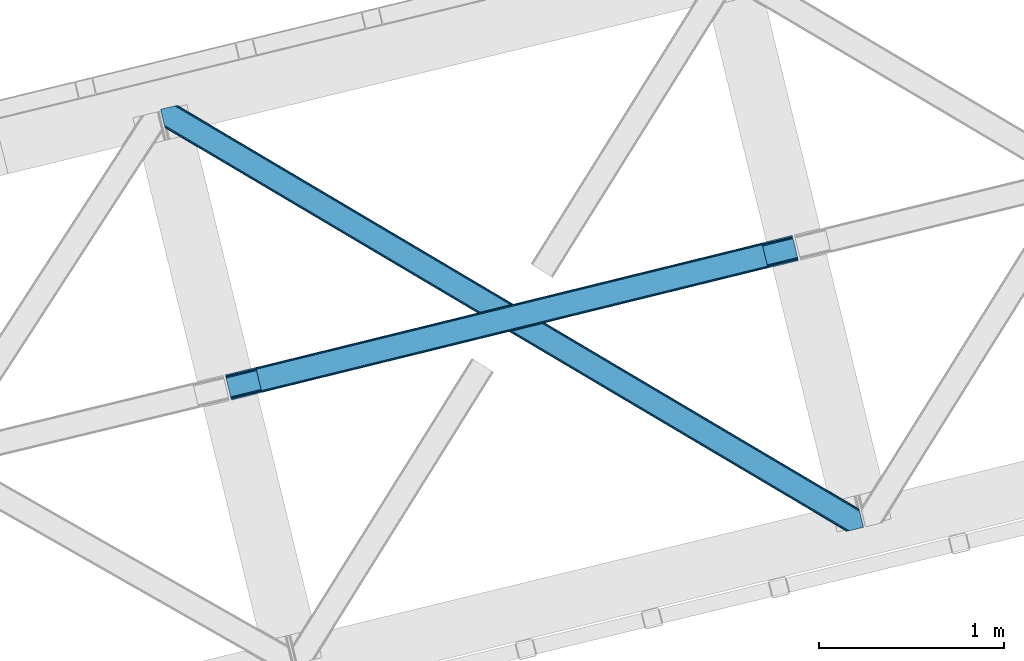
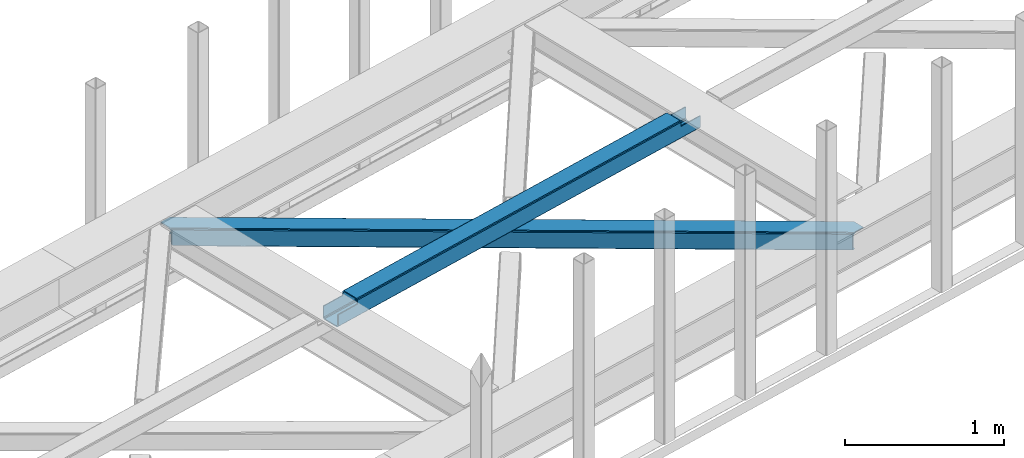
# One storey, part 39 of 66: 1 beam, 1 member.
"""IFC4 building model written with IfcOpenShell, lengths in millimetres."""

import ifcopenshell
import ifcopenshell.guid

model = None  # the IFC model being written
_history = None  # IfcOwnerHistory: only IFC2X3 demands one
_inside = {}  # id of a spatial element -> (the spatial element, [elements in it])
_under = {}  # id of a project, library or spatial element -> (it, [spatial elements below it])
_declared = {}  # id of a project -> (the project, [libraries it declares])
_typed = {}  # id of a type object -> (the type object, [elements of that type])
_made_of = {}  # id of a material, layer set ... -> (it, [elements and type objects made of it])


def new_model(schema):
    """Start an empty IFC model of exactly this schema.

    Asked for "IFC4X3", IfcOpenShell would pick the latest addendum, in which some entities
    have other attributes; the version numbers below select the first issue.
    IFC2X3 requires an IfcOwnerHistory on every rooted entity: one is made here for all.
    """
    global model, _history
    if schema == "IFC4X3":
        model = ifcopenshell.file(schema_version=(4, 3, 0, 0))
    else:
        model = ifcopenshell.file(schema=schema)
    _inside.clear()
    _under.clear()
    _declared.clear()
    _typed.clear()
    _made_of.clear()
    _history = None
    if model.schema == "IFC2X3":
        org = make("IfcOrganization", Name="unknown")
        user = make(
            "IfcPersonAndOrganization",
            ThePerson=make("IfcPerson", FamilyName="unknown"),
            TheOrganization=org,
        )
        app = make(
            "IfcApplication",
            ApplicationDeveloper=org,
            Version="unknown",
            ApplicationFullName="unknown",
            ApplicationIdentifier="unknown",
        )
        _history = make(
            "IfcOwnerHistory",
            OwningUser=user,
            OwningApplication=app,
            ChangeAction="ADDED",
            CreationDate=0,
        )
    return model


def make(cls, **values):
    """One entity of the class cls with the attributes given. An attribute that is None is left unset."""
    return model.create_entity(
        cls, **{name: value for name, value in values.items() if value is not None}
    )


def entity(cls, *values):
    """Any entity or typed value of the class cls, its attributes in the order of the schema. None: left unset."""
    e = model.create_entity(cls)
    for i, value in enumerate(values):
        if value is not None:
            e[i] = value
    return e


def rooted(cls, **values):
    """An entity with a GlobalId (a new one), such as an element, a storey or a relation."""
    return make(cls, GlobalId=ifcopenshell.guid.new(), OwnerHistory=_history, **values)


def si_unit(unit_type, name, prefix=None):
    """IfcSIUnit, for example si_unit("LENGTHUNIT", "METRE", prefix="MILLI")."""
    return make("IfcSIUnit", UnitType=unit_type, Prefix=prefix, Name=name)


def converted_unit(unit_type, name, factor, base, dimensions=None, offset=None):
    """IfcConversionBasedUnit, such as the inch: factor (a typed value) times the base unit."""
    return make(
        "IfcConversionBasedUnit"
        if offset is None
        else "IfcConversionBasedUnitWithOffset",
        ConversionOffset=offset,
        Dimensions=None
        if dimensions is None
        else entity("IfcDimensionalExponents", *dimensions),
        UnitType=unit_type,
        Name=name,
        ConversionFactor=make(
            "IfcMeasureWithUnit", ValueComponent=factor, UnitComponent=base
        ),
    )


def derived_unit(unit_type, elements):
    """IfcDerivedUnit: a product of units, each with its exponent."""
    return make(
        "IfcDerivedUnit",
        Elements=[
            make("IfcDerivedUnitElement", Unit=unit, Exponent=power)
            for unit, power in elements
        ],
        UnitType=unit_type,
    )


def assignment(units):
    """IfcUnitAssignment: the units of a project."""
    return None if units is None else make("IfcUnitAssignment", Units=units)


def point(xyz):
    """IfcCartesianPoint."""
    return None if xyz is None else make("IfcCartesianPoint", Coordinates=xyz)


def direction(xyz):
    """IfcDirection."""
    return None if xyz is None else make("IfcDirection", DirectionRatios=xyz)


def frame(location, z_axis=None, x_axis=None):
    """IfcAxis2Placement3D, a coordinate frame: its origin and axes. An axis left out is left unset."""
    return make(
        "IfcAxis2Placement3D",
        Location=point(location),
        Axis=direction(z_axis),
        RefDirection=direction(x_axis),
    )


def origin():
    """The frame at (0, 0, 0) with its axes left unset."""
    return frame((0.0, 0.0, 0.0))


def place(relative_to, where):
    """IfcLocalPlacement: puts the frame where relative to a parent placement (None: the world)."""
    return make(
        "IfcLocalPlacement", PlacementRelTo=relative_to, RelativePlacement=where
    )


def context(
    kind, dimensions, precision=None, world=None, true_north=None, identifier=None
):
    """IfcGeometricRepresentationContext, for example the 3D "Model" context."""
    return make(
        "IfcGeometricRepresentationContext",
        ContextIdentifier=identifier,
        ContextType=kind,
        CoordinateSpaceDimension=dimensions,
        Precision=precision,
        WorldCoordinateSystem=world,
        TrueNorth=true_north,
    )


def subcontext(parent, identifier, kind, view, scale=None):
    """IfcGeometricRepresentationSubContext, for example "Body" below "Model"."""
    return make(
        "IfcGeometricRepresentationSubContext",
        ContextIdentifier=identifier,
        ContextType=kind,
        ParentContext=parent,
        TargetScale=scale,
        TargetView=view,
    )


def project(units=None, contexts=None):
    """IfcProject with its units and contexts."""
    return rooted(
        "IfcProject",
        Name="project",
        RepresentationContexts=contexts,
        UnitsInContext=assignment(units),
    )


def spatial(cls, under=None, at=None, **own):
    """A site, building, storey or space (cls), placed at a placement, below another one or the project."""
    s = rooted(cls, ObjectPlacement=at, **own)
    if under is not None:
        _under.setdefault(under.id(), (under, []))[1].append(s)
    return s


def point_list(points):
    """IfcCartesianPointList2D or 3D."""
    cls = (
        "IfcCartesianPointList2D" if len(points[0]) == 2 else "IfcCartesianPointList3D"
    )
    return make(cls, CoordList=points)


def triangles(points, corners, closed=None, point_numbers=None):
    """IfcTriangulatedFaceSet: each triangle names its three corners, points numbered from 1."""
    return make(
        "IfcTriangulatedFaceSet",
        Coordinates=point_list(points),
        Closed=closed,
        CoordIndex=corners,
        PnIndex=point_numbers,
    )


def polygons(points, faces, closed=None, point_numbers=None):
    """IfcPolygonalFaceSet: a face is its outer loop, then its inner loops; points numbered from 1."""
    made = []
    for loops in faces:
        if len(loops) == 1:
            made.append(make("IfcIndexedPolygonalFace", CoordIndex=loops[0]))
        else:
            made.append(
                make(
                    "IfcIndexedPolygonalFaceWithVoids",
                    CoordIndex=loops[0],
                    InnerCoordIndices=loops[1:],
                )
            )
    return make(
        "IfcPolygonalFaceSet",
        Coordinates=point_list(points),
        Closed=closed,
        Faces=made,
        PnIndex=point_numbers,
    )


def shape(context_of_items, identifier, shape_type, items):
    """IfcShapeRepresentation: the items that make up one representation, for example the "Body"."""
    return make(
        "IfcShapeRepresentation",
        ContextOfItems=context_of_items,
        RepresentationIdentifier=identifier,
        RepresentationType=shape_type,
        Items=items,
    )


def material(Name=None, Category=None):
    """IfcMaterial."""
    return make("IfcMaterial", Name=Name, Category=Category)


def made_of(thing, what):
    """Note that an element or type object is made of a material, layer set ...; save() writes the relation."""
    if what is not None:
        _made_of.setdefault(what.id(), (what, []))[1].append(thing)
    return thing


def type_object(cls, material=None, **own):
    """A type object (cls), such as IfcWallType, which elements share."""
    return made_of(rooted(cls, **own), material)


def element(
    cls,
    number,
    at=None,
    inside=None,
    cuts=None,
    type_object=None,
    material=None,
    context=None,
    identifier="Body",
    shape_type=None,
    held_by="IfcProductDefinitionShape",
    body=None,
    shapes=None,
    **own,
):
    """One element of the class cls, such as IfcWall. Its Tag is "e" and its number.

    at: its placement. inside: the storey or other place that contains it. cuts: it is an
    opening in that element (IfcRelVoidsElement). A single representation is given by context,
    identifier, shape_type and body (its items); several are given by shapes. held_by: the class
    of the entity that holds the representations. save() writes the other relations.
    """
    e = rooted(cls, Tag="e%d" % number, ObjectPlacement=at, **own)
    if body is not None:
        shapes = [shape(context, identifier, shape_type, body)]
    if shapes is not None:
        e.Representation = make(held_by, Representations=shapes)
    if inside is not None:
        _inside.setdefault(inside.id(), (inside, []))[1].append(e)
    if cuts is not None:
        rooted(
            "IfcRelVoidsElement", RelatingBuildingElement=cuts, RelatedOpeningElement=e
        )
    if type_object is not None:
        _typed.setdefault(type_object.id(), (type_object, []))[1].append(e)
    return made_of(e, material)


def aggregate(whole, parts):
    """IfcRelAggregates: a whole, such as a stair, and the parts it consists of."""
    return rooted("IfcRelAggregates", RelatingObject=whole, RelatedObjects=parts)


def save(model, path):
    """Write the relations noted so far, then the file.

    IfcRelAggregates (storeys below a building ...), IfcRelContainedInSpatialStructure (elements
    in a storey), IfcRelDefinesByType, IfcRelAssociatesMaterial and IfcRelDeclares: one each for
    every whole, place, type object, material and project.
    """
    for whole, parts in _under.values():
        aggregate(whole, parts)
    for where, things in _inside.values():
        rooted(
            "IfcRelContainedInSpatialStructure",
            RelatedElements=things,
            RelatingStructure=where,
        )
    for kind, things in _typed.values():
        rooted("IfcRelDefinesByType", RelatedObjects=things, RelatingType=kind)
    for what, things in _made_of.values():
        rooted("IfcRelAssociatesMaterial", RelatedObjects=things, RelatingMaterial=what)
    for by, libraries in _declared.values():
        rooted("IfcRelDeclares", RelatingContext=by, RelatedDefinitions=libraries)
    model.write(path)


model = new_model("IFC4")

# Units and contexts
model_context = context("Model", 3, precision=0.01, world=origin(), true_north=direction((6.12303176911189e-17, 1.0)))
plan_context = context("Plan", 3, precision=0.01, world=origin(), true_north=direction((6.12303176911189e-17, 1.0)))
body_context = subcontext(model_context, "Body", "Model", "MODEL_VIEW")
ifc_project = project(units=[si_unit("LENGTHUNIT", "METRE", prefix="MILLI"), si_unit("AREAUNIT", "SQUARE_METRE"), si_unit("VOLUMEUNIT", "CUBIC_METRE"), converted_unit("PLANEANGLEUNIT", "DEGREE", entity("IfcRatioMeasure", 0.0174532925199433), si_unit("PLANEANGLEUNIT", "RADIAN"), dimensions=[0, 0, 0, 0, 0, 0, 0]), si_unit("MASSUNIT", "GRAM", prefix="KILO"), derived_unit("MASSDENSITYUNIT", [(si_unit("MASSUNIT", "GRAM", prefix="KILO"), 1), (si_unit("LENGTHUNIT", "METRE"), -3)]), derived_unit("MOMENTOFINERTIAUNIT", [(si_unit("LENGTHUNIT", "METRE"), 4)]), si_unit("TIMEUNIT", "SECOND"), si_unit("FREQUENCYUNIT", "HERTZ"), si_unit("THERMODYNAMICTEMPERATUREUNIT", "DEGREE_CELSIUS"), derived_unit("THERMALTRANSMITTANCEUNIT", [(si_unit("MASSUNIT", "GRAM", prefix="KILO"), 1), (si_unit("THERMODYNAMICTEMPERATUREUNIT", "KELVIN"), -1), (si_unit("TIMEUNIT", "SECOND"), -3)]), derived_unit("VOLUMETRICFLOWRATEUNIT", [(si_unit("LENGTHUNIT", "METRE"), 3), (si_unit("TIMEUNIT", "SECOND"), -1)]), derived_unit("MASSFLOWRATEUNIT", [(si_unit("MASSUNIT", "GRAM", prefix="KILO"), 1), (si_unit("TIMEUNIT", "SECOND"), -1)]), derived_unit("ROTATIONALFREQUENCYUNIT", [(si_unit("TIMEUNIT", "SECOND"), -1)]), si_unit("ELECTRICCURRENTUNIT", "AMPERE"), si_unit("ELECTRICVOLTAGEUNIT", "VOLT"), si_unit("POWERUNIT", "WATT"), si_unit("FORCEUNIT", "NEWTON", prefix="KILO"), si_unit("ILLUMINANCEUNIT", "LUX"), si_unit("LUMINOUSFLUXUNIT", "LUMEN"), si_unit("LUMINOUSINTENSITYUNIT", "CANDELA"), derived_unit("USERDEFINED", [(si_unit("MASSUNIT", "GRAM", prefix="KILO"), -1), (si_unit("LENGTHUNIT", "METRE"), -2), (si_unit("TIMEUNIT", "SECOND"), 3), (si_unit("LUMINOUSFLUXUNIT", "LUMEN"), 1)]), derived_unit("LINEARVELOCITYUNIT", [(si_unit("LENGTHUNIT", "METRE"), 1), (si_unit("TIMEUNIT", "SECOND"), -1)]), si_unit("PRESSUREUNIT", "PASCAL"), derived_unit("USERDEFINED", [(si_unit("LENGTHUNIT", "METRE"), -2), (si_unit("MASSUNIT", "GRAM", prefix="KILO"), 1), (si_unit("TIMEUNIT", "SECOND"), -2)]), derived_unit("LINEARFORCEUNIT", [(si_unit("MASSUNIT", "GRAM", prefix="KILO"), 1), (si_unit("LENGTHUNIT", "METRE"), 1), (si_unit("TIMEUNIT", "SECOND"), -2), (si_unit("LENGTHUNIT", "METRE"), -1)]), derived_unit("PLANARFORCEUNIT", [(si_unit("MASSUNIT", "GRAM", prefix="KILO"), 1), (si_unit("LENGTHUNIT", "METRE"), 1), (si_unit("TIMEUNIT", "SECOND"), -2), (si_unit("LENGTHUNIT", "METRE"), -2)])], contexts=[model_context, plan_context])

# Site, building, storey
site_placement = place(None, origin())
site = spatial("IfcSite", under=ifc_project, at=site_placement, CompositionType="ELEMENT")
building_placement = place(site_placement, origin())
building = spatial("IfcBuilding", under=site, at=building_placement, CompositionType="ELEMENT")
storey_placement = place(building_placement, frame((0.0, 0.0, 19800.0)))
storey = spatial("IfcBuildingStorey", under=building, at=storey_placement, Name="06", CompositionType="ELEMENT", Elevation=19800.0)

# Beam
ifc_material = material(Name="Metal painted (White)")
beam_type = type_object("IfcBeamType", PredefinedType="BEAM")
beam_placement = place(storey_placement, frame((-29806.7, 11867.31, 3967.02)))
element("IfcBeam", 1, at=beam_placement, inside=storey, type_object=beam_type, material=ifc_material, ObjectType="Steel Beam", PredefinedType="BEAM", context=body_context, shape_type="Tessellation", body=[
    polygons([(195.604746583075, 47.1752169465625, 116.423738076669), (195.289267887383, 48.4694323441397, 123.120697582703), (2923.92903262095, 719.782371889898, 122.249440972472), (2924.24451131664, 718.48815649231, 115.552481466434), (194.3908605719, 52.1550459747286, 128.798103947525), (2923.03062530547, 723.467985520489, 127.926847337285), (193.04629900633, 57.6709565732295, 132.591623517896), (2921.6860637399, 728.983896118994, 131.720366907661), (191.46028050054, 64.1774167528979, 133.923727327576), (2920.10004523411, 735.490356298641, 133.052470717336), (169.909056871414, 152.588855745844, 133.923667058171), (2898.54882160498, 823.901795291585, 133.052410447936), (168.323038365632, 159.095315925473, 132.591554377688), (2896.9628030992, 830.40825547123, 131.720297767452), (166.978476800063, 164.611226523979, 128.798027287003), (2895.61824153363, 835.924166069733, 127.926770676772), (166.080069484584, 168.29684015457, 123.120615897284), (2894.71983421815, 839.609779700328, 122.24935928704), (165.764590788888, 169.591055552179, 116.423654626735), (2894.40435552246, 840.903995097923, 115.552398016495), (2892.74656908944, 847.704875020456, 100.498181174067), (2892.74656908944, 847.704875020458, 122.552393716857), (2893.06204778513, 846.410659622874, 129.249354987406), (2893.96045510062, 842.725045992283, 134.92676637713), (2895.30501666619, 837.20913539378, 138.720293467814), (2896.89103517197, 830.70267521412, 140.052406148298), (2921.75783166713, 728.689476376108, 140.052475689917), (2923.3438501729, 722.183016196485, 138.720371880237), (2924.68841173848, 716.667105597982, 134.926852309861), (2925.58681905396, 712.981491967389, 129.249445945048), (2925.90229774989, 711.687276568789, 122.55248643901), (2925.90229774965, 711.687276569775, 100.498181174067), (2924.24451131664, 718.488156492308, 100.498181174067), (2894.40435552246, 840.903995097923, 100.498181174067), (165.764590788884, 169.591055552182, 101.477957282639), (195.60474658307, 47.1752169465668, 101.477957282639), (197.262533018061, 40.37433701599, 101.477957282639), (197.262533016081, 40.3743370240292, 123.423743049245), (196.947054320385, 41.6685524216237, 130.120702555279), (196.048647004907, 45.354166052217, 135.798108920101), (194.704085439337, 50.8700766507178, 139.591628490473), (193.118066933551, 57.3765368303668, 140.923732300152), (168.251270438398, 159.389735668379, 140.923662758538), (166.665251932617, 165.896195848024, 139.59155007805), (165.320690367043, 171.412106446525, 135.798022987369), (164.422283051569, 175.097720077118, 130.120611597646), (164.106804355869, 176.391935474715, 123.423650327093), (164.106804355873, 176.391935474715, 101.477957282639), (3088.35131567249, 758.862493425842, 99.4981811740719), (3088.35131567249, 758.862493425842, 24.5000776734212), (31.4979422272015, 6.80088001302851, 25.4761331214731), (31.4979422272015, 6.80088001302851, 100.477957282644), (194.633700403446, 46.9363155445932, 100.477957282639), (1.65778643301973, 129.216718618645, 25.476049671535), (3058.5111598783, 881.278332031454, 24.499994223483), (3058.51115987832, 881.278332031454, 99.4981811740719), (2895.37540170208, 841.142896499894, 99.4981811740675), (1.65778643301539, 129.216718618643, 100.477957282639), (3090.00910210416, 752.061613508751, 17.5000819730594), (3090.00910210555, 752.061613503148, 99.4981811740762), (2926.87334392953, 711.9261779707, 99.4981811740675), (33.1557286742552, 3.25379915011581e-08, 100.477957282644), (33.1557286629934, 7.91814102285571e-08, 18.4761374211026), (3056.8533734453, 888.07921195399, 99.4981811740719), (3056.85337344529, 888.07921195399, 17.4999892509068), (4.33146851719357e-12, 136.017598541181, 18.4760446989587), (4.33146851719357e-12, 136.017598541179, 100.477957282639), (163.135758176248, 176.153034072741, 100.477957282635), (2925.21555749626, 718.727057894282, 99.4981811740719), (2893.71761526907, 847.943776422432, 99.4981811740719), (3058.826638574, 879.984116633862, 17.8030347174491), (3059.72504588947, 876.298503003269, 12.1256283526317), (3061.06960745504, 870.782592404766, 8.33210878225564), (3062.65562596083, 864.276132225121, 7.00000497257624), (3084.20684958996, 775.864693232179, 7.00006524197628), (3085.79286809575, 769.358233052533, 8.33217792246421), (3087.13742966132, 763.842322454027, 12.1257050131446), (3088.03583697679, 760.156708823439, 17.8031164028683), (3089.69362340981, 753.355828900884, 10.8031207025108), (3088.79521609433, 757.041442531473, 5.12570931278704), (3087.45065452876, 762.557353129978, 1.33218222210669), (3085.86463602297, 769.063813309644, 6.95416144253613e-05), (3060.99783952781, 871.077012147657, 4.33146851719357e-12), (3059.41182102204, 877.583472327284, 1.33210380968372), (3058.06725945647, 883.099382925789, 5.12562338005977), (3057.16885214099, 886.784996556382, 10.8030297448772), (196.291486836457, 40.1354356220577, 100.477957282644), (164.793544609264, 169.352154150206, 100.477957282639), (27.353476144676, 23.8030798193683, 7.97612069002819), (28.9394946504662, 17.296619639702, 9.30823337052045), (30.2840562160316, 11.780709041199, 13.1017604612008), (31.1824635315145, 8.09509541061007, 18.7791718509245), (1.97326512871545, 127.922503221042, 18.7790901655053), (2.87167244418966, 124.236889590447, 13.1016838006879), (4.21623400976372, 118.720978991944, 9.30816423030755), (5.80225251554089, 112.214518812312, 7.97606042062815), (0.31547869569572, 134.723383143586, 11.7790851929161), (1.21388601117427, 131.037769512995, 6.10167882810301), (2.55844757674399, 125.521858914492, 2.3081592577313), (4.14446608252982, 119.015398734848, 0.976055448051909), (29.0112625776828, 17.002199896835, 0.976124989666334), (30.5972810834643, 10.4957397171882, 2.30823767015427), (31.9418426490383, 4.97982911868517, 6.10176476083461), (32.8402499645125, 1.29421548809192, 11.7791761505583)], [[[1, 2, 3, 4]], [[2, 5, 6, 3]], [[5, 7, 8, 6]], [[7, 9, 10, 8]], [[11, 12, 10, 9]], [[11, 13, 14, 12]], [[13, 15, 16, 14]], [[15, 17, 18, 16]], [[17, 19, 20, 18]], [[21, 22, 23, 24, 25, 26, 27, 28, 29, 30, 31, 32, 33, 4, 3, 6, 8, 10, 12, 14, 16, 18, 20, 34]], [[35, 19, 17, 15, 13, 11, 9, 7, 5, 2, 1, 36, 37, 38, 39, 40, 41, 42, 43, 44, 45, 46, 47, 48]], [[42, 41, 28, 27]], [[41, 40, 29, 28]], [[40, 39, 30, 29]], [[39, 38, 31, 30]], [[27, 26, 43, 42]], [[47, 46, 23, 22]], [[46, 45, 24, 23]], [[45, 44, 25, 24]], [[44, 43, 26, 25]], [[33, 49, 50, 51, 52, 53, 1, 4]], [[54, 55, 56, 57, 20, 19, 35, 58]], [[59, 60, 61, 31, 38, 37, 62, 63]], [[64, 65, 66, 67, 68, 47, 22, 21]], [[61, 60, 49, 69]], [[64, 70, 57, 56]], [[65, 64, 56, 55, 71, 72, 73, 74, 75, 76, 77, 78, 50, 49, 60, 59, 79, 80, 81, 82, 83, 84, 85, 86]], [[87, 53, 52, 62]], [[67, 58, 88, 68]], [[89, 90, 76, 75]], [[90, 91, 77, 76]], [[91, 92, 78, 77]], [[92, 51, 50, 78]], [[54, 93, 71, 55]], [[93, 94, 72, 71]], [[94, 95, 73, 72]], [[95, 96, 74, 73]], [[89, 75, 74, 96]], [[66, 97, 98, 99, 100, 101, 102, 103, 104, 63, 62, 52, 51, 92, 91, 90, 89, 96, 95, 94, 93, 54, 58, 67]], [[63, 104, 79, 59]], [[104, 103, 80, 79]], [[103, 102, 81, 80]], [[102, 101, 82, 81]], [[100, 99, 84, 83]], [[99, 98, 85, 84]], [[98, 97, 86, 85]], [[97, 66, 65, 86]], [[83, 82, 101, 100]]], closed=False),
])

# Member
member_type = type_object("IfcMemberType", PredefinedType="BRACE")
member_placement = place(storey_placement, frame((-30155.6, 11159.18, 3823.0)))
element("IfcMember", 2, at=member_placement, inside=storey, type_object=member_type, ObjectType="Steel Horizontal Brace", PredefinedType="BRACE", context=body_context, shape_type="Tessellation", body=[
    triangles([(3167.12993774414, 476.930191040039, 17.5012573242202), (3764.84926757812, 123.064581298828, 122.499499511719), (3764.84926757812, 123.064581298828, 17.5012573242202), (2547.33753662109, 843.86244506836, 17.5012573242202), (1927.54513549805, 1210.79469909668, 17.5012573242202), (91.5037170410142, 2297.77602539063, 122.499499511719), (687.960333251951, 1944.65804443359, 17.5012573242202), (91.5037170410142, 2297.77602539063, 17.5012573242202), (1307.752734375, 1577.726953125, 17.5012573242202), (3770.64426269531, 99.2974273681648, 140.00075683594), (3768.42579345703, 108.393383789062, 138.668280029298), (76.4813781738267, 2294.11345825195, 138.668280029298), (67.1726440429666, 2291.8438293457, 140.00075683594), (3766.5468383789, 116.103378295898, 134.87548828125), (84.376245117186, 2296.03775939941, 134.87548828125), (3765.29110107422, 121.255389404298, 129.196765136719), (89.6526672363252, 2297.32372741699, 129.196765136719), (3722.24256591797, 5.93103332519604, 140.00075683594), (18.7686218261697, 2198.47743530274, 140.00075683594), (3789.41055908203, 22.3044525146488, 140.00075683594), (0.0, 2275.47041015625, 140.00075683594), (3697.91149291992, 0.0, 122.499499511719), (3699.76254272461, 0.451135253906614, 129.196765136719), (24.1217834472627, 2176.5194732666, 129.196765136719), (24.5636169433565, 2174.71028137207, 122.499499511719), (3705.0366394043, 1.73710327148365, 134.87548828125), (22.8660461425752, 2181.671484375, 134.87548828125), (3712.93150634766, 3.66140441894458, 138.668280029298), (20.9870910644531, 2189.38147888184, 138.668280029298), (1862.08634033203, 1086.85342712402, 17.5012573242202), (2481.94152832031, 719.882803344726, 17.5012573242202), (3101.79904174805, 352.91217956543, 17.5012573242202), (3697.91149291992, 0.0, 17.5012573242202), (1242.22882690429, 1453.82405090332, 17.5012573242202), (622.37131347656, 1820.79467468262, 17.5012573242202), (24.5636169433565, 2174.71028137207, 17.5012573242202), (74.6442810058579, 2293.66581115723, 127.873590087893), (66.7494140624985, 2291.74151000977, 131.668707275392), (79.9183776855461, 2294.9517791748, 122.197192382813), (57.4383544921875, 2289.47188110352, 133.001184082033), (0.0, 2275.47041015625, 133.001184082033), (81.771752929686, 2295.40291442871, 115.499926757813), (81.771752929686, 2295.40291442871, 24.5008300781265), (79.9183776855461, 2294.9517791748, 17.8035644531265), (89.5643005371094, 2297.30279846191, 10.8156188964858), (89.4712829589844, 2297.27954406738, 10.4993591308594), (74.1164062499993, 2293.53674926758, 12.4271484375022), (72.0374633789033, 2293.03096618652, 10.4993591308594), (1922.1942993164, 1205.8275604248, 24.5008300781265), (3767.16773071289, 113.558184814454, 115.499926757813), (2545.11209106445, 837.045419311524, 24.5008300781265), (3168.0298828125, 468.263278198243, 24.5008300781265), (3767.16773071289, 113.558184814454, 24.5008300781265), (1299.27883300781, 1574.60853881836, 24.5008300781265), (676.361041259763, 1943.39067993164, 24.5008300781265), (3767.60956420898, 111.748992919922, 122.197192382813), (3768.86530151367, 106.596981811523, 127.873590087893), (3770.7442565918, 98.8869873046879, 131.668707275392), (3772.96040039062, 89.7910308837891, 133.001184082033), (3767.6979309082, 111.385061645507, 17.8686767578147), (3767.80490112305, 110.943228149414, 16.5199218750022), (3764.85856933594, 123.027374267578, 16.5199218750022), (3789.41055908203, 22.3044525146488, 133.001184082033), (3731.97685546875, 8.30414428710901, 133.001184082033), (16.4524841308594, 2207.98383178711, 133.001184082033), (162.741229248044, 2253.90428466797, 10.4993591308594), (166.892138671872, 2236.87509155273, 10.4993591308594), (3722.66579589844, 6.03451538085938, 131.668707275392), (18.6686279296846, 2198.88903808594, 131.668707275392), (3714.77092895508, 4.11021423339844, 127.873590087893), (20.5475830078103, 2191.17788085938, 127.873590087893), (3709.49683227539, 2.82424621581958, 122.197192382813), (21.8033203124978, 2186.02586975098, 122.197192382813), (3707.64345703125, 2.3719482421875, 115.499926757813), (22.2451538085916, 2184.21667785645, 115.499926757813), (3114.18665771484, 353.712130737305, 24.5008300781265), (3707.64345703125, 2.3719482421875, 24.5008300781265), (2491.12236328125, 722.583801269531, 24.5008300781265), (1868.05341796875, 1091.45430908203, 24.5008300781265), (621.920178222656, 1829.19532470703, 24.5008300781265), (22.2451538085916, 2184.21667785645, 24.5008300781265), (1244.9867980957, 1460.32481689453, 24.5008300781265), (3709.49683227539, 2.82424621581958, 17.8035644531265), (3700.13693847656, 0.541827392578853, 10.8691040039084), (3700.58807373047, 0.65228576660229, 9.52034912109593), (3714.77092895508, 4.11021423339844, 12.1248413085959), (3719.39622802734, 5.23688964843677, 9.52034912109593), (21.7823913574211, 2186.11191101074, 17.817517089843), (21.7614624023408, 2186.20144042969, 17.5012573242202), (32.1398986816384, 2171.84650268555, 10.8179443359368), (28.3494323730447, 2188.73965759277, 10.4993591308594), (27.0146301269524, 2187.35137023926, 12.1248413085959), (32.5003417968728, 2171.71046447754, 10.4993591308594), (203.968945312499, 2084.76809692383, 10.4993591308594), (208.119854736327, 2067.74006652832, 10.4993591308594), (164.099285888671, 2252.54739074707, 9.49942016601563), (168.587384033202, 2234.14502563477, 9.49942016601563), (168.16880493164, 2234.81707763672, 9.74591674804833), (163.771398925779, 2252.87527770996, 9.74126586914281), (167.738598632812, 2235.51005859375, 9.9993896484375), (163.420257568359, 2253.22641906738, 9.9993896484375), (167.306066894529, 2236.20187683106, 10.2528625488303), (163.066790771481, 2253.5775604248, 10.2598388671868), (209.166302490234, 2067.67146606445, 9.49942016601563), (209.136071777342, 2067.46682739258, 9.88311767578125), (204.682855224608, 2085.44363708496, 9.8528869628899), (208.803533935545, 2067.5551940918, 10.0831054687515), (204.685180664063, 2084.81111755371, 10.2063537597678), (208.45006713867, 2067.65053710938, 10.2993713378928), (204.327062988279, 2084.79018859863, 10.3528564453118), (204.680529785153, 2086.07499389648, 9.49942016601563), (3763.57725219726, 109.725860595703, 12.1248413085959), (3758.57058105469, 124.97144165039, 10.8714294433594), (3757.06834716797, 125.43536682129, 9.52034912109593), (3761.54714355469, 107.063232421875, 9.52034912109593), (3585.92763061524, 211.034793090821, 9.52034912109593), (3581.44883422851, 229.405764770509, 9.52034912109593), (3585.50905151367, 211.134786987304, 9.44360961914208), (3581.04885864258, 229.553430175782, 9.37384643554833), (3580.64888305664, 229.701095581055, 9.22734375000073), (3580.53958740234, 229.532501220703, 8.87387695312646), (3585.46021728516, 210.476687622071, 9.13897705078125), (3580.43029174805, 229.365069580079, 8.52041015625218), (3585.40673217773, 209.805798339843, 8.82736816406396), (3585.35789794922, 209.14769897461, 8.52041015625218), (3164.51846923828, 472.519995117187, 5.12526855468968), (3581.30465698242, 225.771102905273, 5.12526855468968), (3166.45090942383, 475.783749389648, 10.8039916992202), (687.281304931639, 1943.5116027832, 10.8039916992202), (685.348864746091, 1940.24784851074, 5.12526855468968), (165.157360839843, 2248.2150970459, 5.12526855468968), (682.456018066405, 1935.36210021973, 1.33247680664135), (167.036315917969, 2240.50510253906, 1.33247680664135), (679.046923828122, 1929.59966125488, 0.0), (169.252459716794, 2231.41030883789, 0.0), (3583.18361206055, 218.061108398437, 1.33247680664135), (3585.40208129883, 208.966314697265, 0.0), (3158.21420288086, 461.870645141602, 0.0), (3161.62562255859, 467.634246826172, 1.33247680664135), (2546.65850830078, 842.716003417969, 10.8039916992202), (1926.86610717774, 1209.64825744629, 10.8039916992202), (1307.07370605469, 1576.58051147461, 10.8039916992202), (2544.72606811523, 839.452249145508, 5.12526855468968), (1924.93366699219, 1206.3833404541, 5.12526855468968), (1305.14126586914, 1573.31559448242, 5.12526855468968), (2541.83322143555, 834.566500854493, 1.33247680664135), (1922.0408203125, 1201.49875488281, 1.33247680664135), (1302.24841918945, 1568.42984619141, 1.33247680664135), (2538.42180175781, 828.802899169921, 0.0), (1918.63172607422, 1195.73515319824, 0.0), (1298.83932495117, 1562.66740722656, 0.0), (3620.16275024414, 66.3657165527347, 0.0), (3110.71477661133, 367.97056274414, 0.0), (2490.85726318359, 734.941186523438, 0.0), (1870.99974975586, 1101.91181030273, 0.0), (631.287048339844, 1835.85305786133, 0.0), (1251.14223632812, 1468.88243408203, 0.0), (204.013128662107, 2088.80971069336, 0.0), (3167.34852905274, 467.116836547852, 17.8035644531265), (3165.41608886719, 463.851919555664, 12.1248413085959), (673.749572753906, 1938.98048400879, 12.1248413085959), (675.684338378906, 1942.24423828125, 17.8035644531265), (670.859051513671, 1934.09473571777, 8.3320495605476), (169.401287841796, 2230.8022064209, 8.81806640624927), (171.570922851563, 2221.90391235351, 6.99957275390625), (3159.11182250976, 453.203732299804, 6.99957275390625), (3587.71821899414, 199.458755493164, 6.99957275390625), (3585.50905151367, 208.524481201172, 8.42274169921802), (3162.52556762695, 458.967333984376, 8.3320495605476), (667.447631835938, 1928.33229675293, 6.99957275390625), (2536.19635620117, 821.985873413087, 6.99957275390625), (2539.60777587891, 827.749475097657, 8.3320495605476), (1916.69230957031, 1196.53161621094, 8.3320495605476), (1913.27856445313, 1190.76801452637, 6.99957275390625), (1293.77451782226, 1565.31259460449, 8.3320495605476), (1290.36309814453, 1559.55015563965, 6.99957275390625), (2542.50062255859, 832.635223388672, 12.1248413085959), (1919.58515625, 1201.41620178223, 12.1248413085959), (1296.66736450195, 1570.19834289551, 12.1248413085959), (2544.43306274414, 835.898977661132, 17.8035644531265), (1921.51527099609, 1204.68111877441, 17.8035644531265), (1298.5998046875, 1573.4632598877, 17.8035644531265), (201.696990966797, 2098.31610717773, 6.99957275390625), (203.864300537109, 2089.41781311035, 8.81806640624927), (206.229272460936, 2079.71491699219, 1.33247680664135), (208.110552978513, 2072.00492248535, 5.12526855468968), (2500.03577270508, 737.642184448243, 6.99957275390625), (3123.10471801758, 368.771676635743, 6.99957275390625), (1876.96915283203, 1106.51269226074, 6.99957275390625), (3617.84428710938, 75.8721130371086, 6.99957275390625), (630.835913085935, 1844.25487060547, 6.99957275390625), (1253.90253295898, 1475.38320007324, 6.99957275390625), (3119.69329833984, 363.009237670898, 8.3320495605476), (3620.56505126953, 65.0402160644535, 8.90410766601781), (3620.20693359375, 66.1831695556648, 8.52041015625218), (3116.80045166015, 358.123489379883, 12.1248413085959), (3621.05571899414, 64.3216552734375, 9.1087463378899), (3621.55103759766, 63.5914672851559, 9.31571044922021), (3622.04170532227, 62.8729064941399, 9.52034912109593), (3620.05345458984, 66.8075500488285, 8.42274169921802), (624.531646728516, 1833.60552062988, 12.1248413085959), (627.424493408202, 1838.4912689209, 8.3320495605476), (622.601531982422, 1830.34176635742, 17.8035644531265), (3114.86801147461, 354.858572387695, 17.8035644531265), (2491.79906616211, 723.729080200195, 17.8035644531265), (1868.73477172852, 1092.60075073242, 17.8035644531265), (1245.66582641601, 1461.47125854492, 17.8035644531265), (2493.73150634766, 726.993997192383, 12.1248413085959), (1870.66488647461, 1095.86450500488, 12.1248413085959), (1247.59826660156, 1464.73501281738, 12.1248413085959), (2496.62435302734, 731.879745483398, 8.3320495605476), (1873.5577331543, 1100.7502532959, 8.3320495605476), (1250.49111328125, 1469.6207611084, 8.3320495605476), (3102.47807006836, 354.057458496094, 10.8039916992202), (624.98278198242, 1825.20487060547, 5.12526855468968), (623.050341796872, 1821.94111633301, 10.8039916992202), (3626.52050170898, 44.5019348144524, 9.52034912109593), (3104.41051025391, 357.322375488282, 5.12526855468968), (3624.25784912109, 49.5597656249993, 5.12526855468968), (3625.13453979492, 45.9657989501957, 8.52041015625218), (3625.82752075195, 45.2344482421868, 9.02037963867406), (3622.37889404297, 57.2709228515632, 1.33247680664135), (3107.30335693359, 362.208123779297, 1.33247680664135), (627.875628662106, 1830.09061889648, 1.33247680664135), (2487.44584350586, 729.178747558593, 1.33247680664135), (1867.58833007812, 1096.14937133789, 1.33247680664135), (1247.73081665039, 1463.11999511719, 1.33247680664135), (2484.55299682617, 724.292999267578, 5.12526855468968), (1864.69548339844, 1091.26362304687, 5.12526855468968), (1244.84029541015, 1458.23424682617, 5.12526855468968), (2482.62055664062, 721.029244995118, 10.8039916992202), (1862.76304321289, 1087.99870605469, 10.8039916992202), (1242.90552978516, 1454.97049255371, 10.8039916992202)], [[1, 2, 3], [2, 1, 4], [2, 5, 6], [5, 2, 4], [7, 8, 6], [9, 6, 5], [6, 9, 7], [10, 11, 12], [12, 13, 10], [11, 14, 15], [15, 12, 11], [14, 16, 17], [17, 15, 14], [16, 2, 6], [6, 17, 16], [18, 10, 19], [18, 20, 10], [13, 19, 10], [21, 19, 13], [22, 23, 24], [24, 25, 22], [23, 26, 27], [27, 24, 23], [26, 28, 29], [29, 27, 26], [28, 18, 19], [19, 29, 28], [30, 22, 25], [22, 31, 32], [30, 31, 22], [32, 33, 22], [34, 25, 35], [25, 34, 30], [36, 35, 25], [37, 38, 12], [15, 37, 12], [15, 17, 39], [37, 15, 39], [39, 17, 6], [38, 13, 12], [21, 40, 41], [21, 13, 40], [38, 40, 13], [39, 6, 42], [43, 8, 44], [6, 43, 42], [8, 45, 44], [6, 8, 43], [46, 44, 45], [46, 47, 44], [46, 48, 47], [49, 50, 42], [50, 51, 52], [49, 51, 50], [52, 53, 50], [54, 42, 55], [42, 54, 49], [43, 55, 42], [50, 56, 42], [39, 42, 56], [56, 57, 39], [37, 39, 57], [57, 58, 37], [38, 37, 58], [58, 59, 38], [40, 38, 59], [57, 14, 11], [59, 58, 10], [58, 57, 11], [60, 61, 62], [63, 59, 20], [10, 20, 59], [58, 11, 10], [60, 3, 53], [2, 50, 53], [53, 3, 2], [60, 62, 3], [2, 56, 50], [56, 14, 57], [14, 56, 16], [2, 16, 56], [59, 64, 65], [64, 59, 63], [65, 40, 59], [41, 40, 65], [66, 67, 46], [48, 46, 67], [64, 68, 65], [69, 65, 68], [68, 70, 69], [71, 69, 70], [70, 72, 71], [73, 71, 72], [72, 74, 73], [75, 73, 74], [76, 74, 77], [74, 76, 78], [74, 79, 75], [79, 74, 78], [80, 81, 75], [82, 75, 79], [75, 82, 80], [70, 68, 28], [26, 70, 28], [26, 23, 72], [70, 26, 72], [72, 23, 22], [68, 18, 28], [20, 64, 63], [20, 18, 64], [68, 64, 18], [72, 22, 74], [77, 33, 83], [22, 77, 74], [33, 84, 83], [22, 33, 77], [85, 83, 84], [86, 83, 85], [87, 86, 85], [73, 75, 25], [25, 24, 73], [27, 73, 24], [73, 27, 71], [25, 81, 36], [88, 89, 36], [36, 81, 88], [75, 81, 25], [69, 29, 19], [21, 65, 19], [41, 65, 21], [69, 71, 29], [29, 71, 27], [65, 69, 19], [90, 91, 92], [90, 93, 91], [92, 36, 90], [89, 36, 92], [94, 95, 93], [93, 91, 94], [96, 97, 98], [98, 99, 96], [99, 98, 100], [100, 101, 99], [101, 100, 102], [102, 103, 101], [103, 102, 67], [67, 66, 103], [104, 105, 106], [105, 107, 108], [108, 107, 109], [110, 109, 95], [95, 94, 110], [109, 110, 108], [108, 106, 105], [106, 111, 104], [62, 112, 113], [112, 62, 61], [112, 114, 113], [112, 115, 114], [114, 115, 116], [116, 117, 114], [118, 119, 117], [120, 119, 118], [121, 120, 122], [123, 121, 124], [124, 125, 123], [122, 124, 121], [118, 122, 120], [117, 116, 118], [1, 3, 113], [3, 62, 113], [120, 121, 126], [123, 126, 121], [123, 127, 126], [128, 113, 117], [117, 126, 128], [117, 119, 126], [120, 126, 119], [113, 114, 117], [45, 129, 66], [129, 130, 131], [131, 96, 129], [129, 99, 101], [99, 129, 96], [129, 103, 66], [103, 129, 101], [129, 45, 8], [8, 7, 129], [66, 46, 45], [130, 132, 133], [133, 131, 130], [132, 134, 135], [135, 133, 132], [136, 137, 138], [138, 139, 136], [127, 136, 139], [139, 126, 127], [113, 128, 1], [1, 128, 4], [140, 4, 128], [4, 140, 141], [141, 5, 4], [5, 141, 142], [142, 9, 5], [9, 142, 7], [129, 7, 142], [128, 126, 140], [143, 140, 126], [140, 143, 141], [144, 141, 143], [141, 144, 145], [145, 142, 141], [142, 145, 130], [130, 129, 142], [126, 139, 143], [146, 143, 139], [143, 146, 147], [147, 144, 143], [144, 147, 145], [148, 145, 147], [145, 148, 130], [132, 130, 148], [139, 138, 146], [149, 146, 138], [146, 149, 147], [150, 147, 149], [147, 150, 148], [151, 148, 150], [148, 151, 134], [134, 132, 148], [137, 152, 153], [138, 153, 154], [153, 138, 137], [149, 155, 150], [154, 149, 138], [149, 154, 155], [156, 134, 151], [150, 157, 151], [157, 150, 155], [157, 156, 151], [158, 134, 156], [135, 134, 158], [159, 160, 112], [112, 61, 159], [159, 60, 53], [161, 162, 44], [98, 163, 100], [98, 97, 163], [163, 102, 100], [163, 67, 102], [97, 164, 163], [161, 47, 67], [67, 163, 161], [47, 48, 67], [163, 164, 165], [166, 167, 168], [160, 118, 116], [116, 112, 160], [116, 115, 112], [169, 168, 125], [125, 160, 169], [124, 122, 160], [122, 118, 160], [160, 125, 124], [168, 169, 166], [165, 170, 163], [44, 47, 161], [162, 55, 43], [43, 44, 162], [53, 52, 159], [61, 60, 159], [166, 169, 171], [172, 171, 169], [171, 172, 173], [173, 174, 171], [174, 173, 175], [175, 176, 174], [176, 175, 163], [163, 170, 176], [169, 160, 172], [177, 172, 160], [172, 177, 178], [178, 173, 172], [173, 178, 175], [179, 175, 178], [175, 179, 163], [161, 163, 179], [160, 159, 180], [180, 177, 160], [177, 180, 178], [181, 178, 180], [178, 181, 182], [182, 179, 178], [179, 182, 162], [162, 161, 179], [159, 52, 51], [51, 180, 159], [180, 51, 49], [49, 181, 180], [181, 49, 54], [54, 182, 181], [182, 54, 162], [55, 162, 54], [97, 131, 133], [135, 97, 133], [165, 164, 135], [165, 135, 183], [131, 97, 96], [135, 164, 97], [183, 158, 184], [158, 185, 111], [158, 183, 135], [186, 111, 185], [158, 111, 184], [186, 104, 111], [187, 188, 166], [166, 171, 187], [171, 189, 187], [189, 171, 174], [188, 167, 166], [188, 190, 167], [170, 191, 176], [191, 170, 183], [165, 183, 170], [192, 176, 191], [174, 192, 189], [176, 192, 174], [193, 194, 195], [196, 197, 194], [196, 198, 197], [196, 199, 198], [194, 193, 196], [195, 200, 193], [86, 87, 199], [199, 196, 86], [193, 200, 190], [191, 183, 184], [201, 108, 110], [110, 94, 201], [94, 92, 201], [94, 91, 92], [202, 106, 108], [202, 111, 106], [202, 184, 111], [108, 201, 202], [203, 201, 92], [92, 89, 203], [203, 88, 81], [81, 80, 203], [89, 88, 203], [184, 202, 191], [190, 188, 193], [83, 86, 196], [196, 204, 83], [77, 83, 204], [204, 76, 77], [76, 204, 205], [205, 78, 76], [78, 205, 206], [206, 79, 78], [79, 206, 207], [207, 82, 79], [82, 207, 203], [203, 80, 82], [204, 196, 205], [208, 205, 196], [205, 208, 209], [209, 206, 205], [206, 209, 207], [210, 207, 209], [207, 210, 203], [201, 203, 210], [196, 193, 211], [211, 208, 196], [208, 211, 209], [212, 209, 211], [209, 212, 213], [213, 210, 209], [210, 213, 202], [202, 201, 210], [193, 188, 187], [187, 211, 193], [211, 187, 189], [189, 212, 211], [212, 189, 213], [192, 213, 189], [213, 192, 202], [191, 202, 192], [214, 84, 33], [35, 36, 90], [215, 105, 104], [216, 90, 95], [95, 215, 216], [95, 107, 215], [104, 186, 215], [84, 214, 217], [214, 218, 219], [219, 220, 214], [221, 217, 214], [214, 220, 221], [217, 85, 84], [222, 219, 218], [218, 223, 222], [152, 222, 223], [223, 153, 152], [156, 224, 185], [185, 158, 156], [224, 215, 186], [186, 185, 224], [90, 216, 35], [33, 32, 214], [153, 223, 225], [225, 154, 153], [154, 225, 226], [226, 155, 154], [155, 226, 227], [227, 157, 155], [157, 227, 224], [224, 156, 157], [223, 218, 225], [228, 225, 218], [225, 228, 226], [229, 226, 228], [226, 229, 227], [230, 227, 229], [227, 230, 224], [215, 224, 230], [218, 214, 231], [231, 228, 218], [228, 231, 232], [232, 229, 228], [229, 232, 233], [233, 230, 229], [230, 233, 216], [216, 215, 230], [214, 32, 31], [31, 231, 214], [231, 31, 232], [30, 232, 31], [232, 30, 233], [34, 233, 30], [233, 34, 216], [35, 216, 34], [137, 167, 190], [125, 127, 123], [137, 125, 167], [125, 136, 127], [125, 137, 136], [152, 137, 190], [195, 152, 190], [219, 195, 220], [195, 222, 152], [195, 219, 222], [220, 195, 194], [221, 194, 197], [221, 197, 198], [217, 198, 199], [87, 85, 199], [217, 199, 85]]),
])

save(model, "model.ifc")
